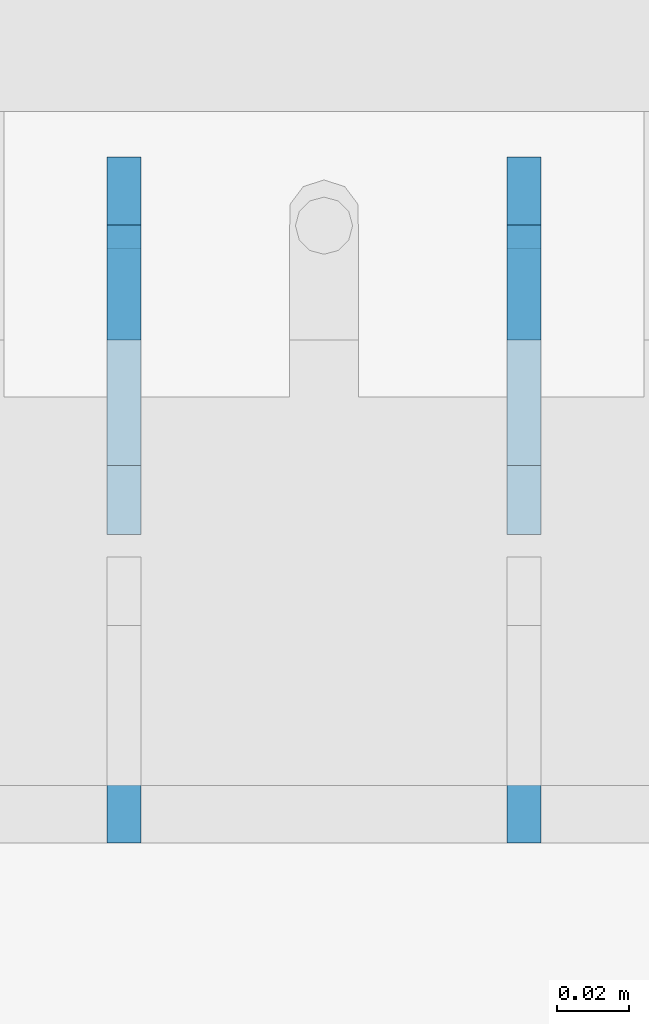
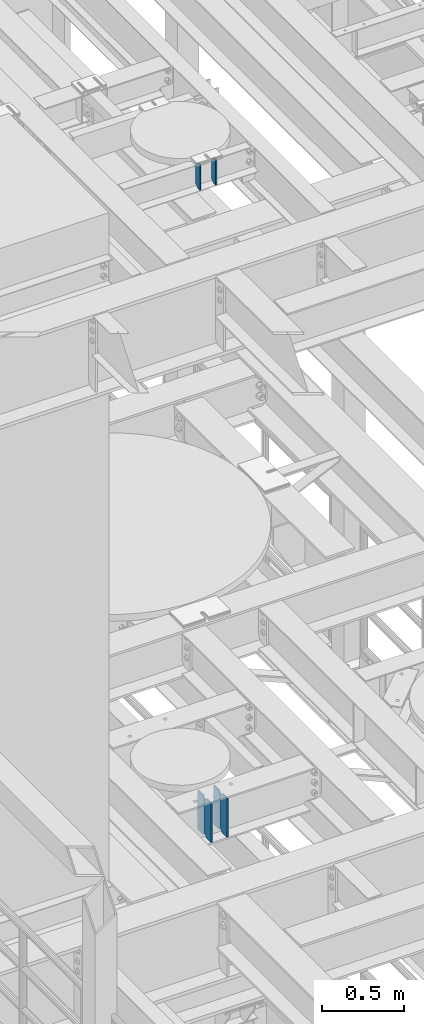
# One storey, part 1606 of 1876: 6 plates, 2 elements without a shape of their own.
"""IFC2X3 building model written with IfcOpenShell, lengths in millimetres."""

from ifc_helpers import new_model, si_unit, frame, origin_with_axes, place, context, subcontext, project, spatial, faceted_brep, material, type_object, element, aggregate, save


model = new_model("IFC2X3")

# Units and contexts
model_context = context("Model", 3, precision=1e-05, world=origin_with_axes())
body_context = subcontext(model_context, "Body", "Model", "MODEL_VIEW")
ifc_project = project(units=[si_unit("LENGTHUNIT", "METRE", prefix="MILLI"), si_unit("AREAUNIT", "SQUARE_METRE"), si_unit("VOLUMEUNIT", "CUBIC_METRE"), si_unit("MASSUNIT", "GRAM", prefix="KILO"), si_unit("TIMEUNIT", "SECOND"), si_unit("PLANEANGLEUNIT", "RADIAN"), si_unit("SOLIDANGLEUNIT", "STERADIAN"), si_unit("THERMODYNAMICTEMPERATUREUNIT", "DEGREE_CELSIUS"), si_unit("LUMINOUSINTENSITYUNIT", "LUMEN")], contexts=[model_context])

# Site, building, storey
site_placement = place(None, origin_with_axes())
site = spatial("IfcSite", under=ifc_project, at=site_placement, CompositionType="ELEMENT")
building_placement = place(site_placement, origin_with_axes())
building = spatial("IfcBuilding", under=site, at=building_placement, Name="Undefined", CompositionType="ELEMENT")
storey_placement = place(building_placement, origin_with_axes())
storey = spatial("IfcBuildingStorey", under=building, at=storey_placement, Name="Undefined", CompositionType="ELEMENT", Elevation=0.0)

# Assembly, plates
assembly_1_placement = place(storey_placement, origin_with_axes())
assembly_1 = element("IfcElementAssembly", 1, at=assembly_1_placement, inside=storey, Name="BEAM", AssemblyPlace="NOTDEFINED", PredefinedType="RIGID_FRAME")
ifc_material = material(Name="STEEL/A36")
plate_type_1 = type_object("IfcPlateType", PredefinedType="NOTDEFINED")
plate_1_placement = place(assembly_1_placement, frame((2544.762, 2336.8, 13006.3875), z_axis=(0.0, 0.0, 1.0), x_axis=(0.0, 1.0, 0.0)))
plate_1 = element("IfcPlate", 2, at=plate_1_placement, type_object=plate_type_1, material=ifc_material, Name="PLATE", context=body_context, shape_type="Brep", body=[
    faceted_brep([(0.0, -4.76249999999982, 0.0), (0.0, -4.76249999999982, 292.100006103516), (0.0, 4.76249999999982, 292.100006103516), (0.0, 4.76249999999982, 0.0), (60.3250007629395, -4.76249999999982, 292.100006103516), (60.3250007629395, 4.76249999999982, 292.100006103516), (79.375, -4.76249999999982, 273.050006866455), (79.375, 4.76249999999982, 273.050006866455), (79.375, -4.76249999999982, 19.0499992370605), (79.375, 4.76249999999982, 19.0499992370605), (60.3250007629395, -4.76249999999982, 0.0), (60.3250007629395, 4.76249999999982, 0.0)], [[[0, 1, 2, 3]], [[1, 4, 5, 2]], [[4, 6, 7, 5]], [[6, 8, 9, 7]], [[8, 10, 11, 9]], [[10, 0, 3, 11]], [[5, 7, 9, 11, 3, 2]], [[10, 8, 6, 4, 1, 0]]]),
])
plate_2_placement = place(assembly_1_placement, frame((2544.762, 2422.525, 13006.3875), z_axis=(0.0, 0.0, 1.0), x_axis=(0.0, 1.0, 0.0)))
plate_2 = element("IfcPlate", 3, at=plate_2_placement, type_object=plate_type_1, material=ifc_material, Name="PLATE", context=body_context, shape_type="Brep", body=[
    faceted_brep([(0.0, -4.76249999999982, 19.0499992370605), (0.0, -4.76249999999982, 273.050006866455), (0.0, 4.76249999999982, 273.050006866455), (0.0, 4.76249999999982, 19.0499992370605), (19.0499992370605, -4.76249999999982, 292.100006103516), (19.0499992370605, 4.76249999999982, 292.100006103516), (79.375, -4.76249999999982, 292.100006103516), (79.375, 4.76249999999982, 292.100006103516), (79.375, -4.76250000000073, 0.0), (79.375, 4.76250000000073, 0.0), (19.0499992370605, -4.76249999999982, 0.0), (19.0499992370605, 4.76249999999982, 0.0)], [[[0, 1, 2, 3]], [[1, 4, 5, 2]], [[4, 6, 7, 5]], [[6, 8, 9, 7]], [[8, 10, 11, 9]], [[10, 0, 3, 11]], [[5, 7, 9, 11, 3, 2]], [[10, 8, 6, 4, 1, 0]]]),
])
plate_3_placement = place(assembly_1_placement, frame((2433.6375, 2336.8, 13006.3875), z_axis=(0.0, 0.0, 1.0), x_axis=(0.0, 1.0, 0.0)))
plate_3 = element("IfcPlate", 4, at=plate_3_placement, type_object=plate_type_1, material=ifc_material, Name="PLATE", context=body_context, shape_type="Brep", body=[
    faceted_brep([(0.0, -4.76249999999982, 0.0), (0.0, -4.76249999999982, 292.100006103516), (0.0, 4.76249999999982, 292.100006103516), (0.0, 4.76249999999982, 0.0), (60.3250007629395, -4.76249999999982, 292.100006103516), (60.3250007629395, 4.76249999999982, 292.100006103516), (79.375, -4.76249999999982, 273.050006866455), (79.375, 4.76249999999982, 273.050006866455), (79.375, -4.76249999999982, 19.0499992370605), (79.375, 4.76249999999982, 19.0499992370605), (60.3250007629395, -4.76249999999982, 0.0), (60.3250007629395, 4.76249999999982, 0.0)], [[[0, 1, 2, 3]], [[1, 4, 5, 2]], [[4, 6, 7, 5]], [[6, 8, 9, 7]], [[8, 10, 11, 9]], [[10, 0, 3, 11]], [[5, 7, 9, 11, 3, 2]], [[10, 8, 6, 4, 1, 0]]]),
])
plate_4_placement = place(assembly_1_placement, frame((2433.6375, 2422.525, 13006.3875), z_axis=(0.0, 0.0, 1.0), x_axis=(0.0, 1.0, 0.0)))
plate_4 = element("IfcPlate", 5, at=plate_4_placement, type_object=plate_type_1, material=ifc_material, Name="PLATE", context=body_context, shape_type="Brep", body=[
    faceted_brep([(0.0, -4.76249999999982, 19.0499992370605), (0.0, -4.76249999999982, 273.050006866455), (0.0, 4.76249999999982, 273.050006866455), (0.0, 4.76249999999982, 19.0499992370605), (19.0499992370605, -4.76249999999982, 292.100006103516), (19.0499992370605, 4.76249999999982, 292.100006103516), (79.375, -4.76249999999982, 292.100006103516), (79.375, 4.76249999999982, 292.100006103516), (79.375, -4.76250000000073, 0.0), (79.375, 4.76250000000073, 0.0), (19.0499992370605, -4.76249999999982, 0.0), (19.0499992370605, 4.76249999999982, 0.0)], [[[0, 1, 2, 3]], [[1, 4, 5, 2]], [[4, 6, 7, 5]], [[6, 8, 9, 7]], [[8, 10, 11, 9]], [[10, 0, 3, 11]], [[5, 7, 9, 11, 3, 2]], [[10, 8, 6, 4, 1, 0]]]),
])
aggregate(assembly_1, [plate_1, plate_2, plate_3, plate_4])

assembly_2_placement = place(storey_placement, origin_with_axes())
assembly_2 = element("IfcElementAssembly", 6, at=assembly_2_placement, inside=storey, Name="BEAM", AssemblyPlace="NOTDEFINED", PredefinedType="RIGID_FRAME")
plate_type_2 = type_object("IfcPlateType", PredefinedType="NOTDEFINED")
plate_5_placement = place(assembly_2_placement, frame((2433.6375, 2476.5, 17784.2356641849), z_axis=(0.0, -0.164348325034458, 0.986402366206797), x_axis=(0.0, 0.986402366206797, 0.164348325034458)))
plate_5 = element("IfcPlate", 7, at=plate_5_placement, type_object=plate_type_2, material=ifc_material, Name="PLATE", context=body_context, shape_type="Brep", body=[
    faceted_brep([(0.0, -4.76249999999982, 0.0), (32.0008087158794, -4.76249999999982, 192.081680297815), (32.0008087158794, 4.76249999999982, 192.081680297815), (0.0, 4.76249999999982, 0.0), (62.6982748962027, -4.76249999999982, 181.561281061485), (62.6982748962027, 4.76249999999982, 181.561281061485), (77.5887637589458, -4.76249999999982, 156.594231983478), (77.5887637589458, 4.76249999999982, 156.594231983478), (54.6307491805464, -4.76249999999982, 18.791006663906), (54.6307491805464, 4.76249999999982, 18.791006663906), (32.4501686096137, -4.76249999999982, -1.63709046319127e-11), (32.4501686096137, 4.76249999999982, -1.63709046319127e-11)], [[[0, 1, 2, 3]], [[1, 4, 5, 2]], [[4, 6, 7, 5]], [[6, 8, 9, 7]], [[8, 10, 11, 9]], [[10, 0, 3, 11]], [[5, 7, 9, 11, 3, 2]], [[10, 8, 6, 4, 1, 0]]]),
])
plate_6_placement = place(assembly_2_placement, frame((2544.7625, 2476.5, 17784.2355895931), z_axis=(0.0, -0.164348325034458, 0.986402366206797), x_axis=(0.0, 0.986402366206797, 0.164348325034458)))
plate_6 = element("IfcPlate", 8, at=plate_6_placement, type_object=plate_type_2, material=ifc_material, Name="PLATE", context=body_context, shape_type="Brep", body=[
    faceted_brep([(0.0, -4.76249999999982, 0.0), (32.0008087158794, -4.76249999999982, 192.081680297815), (32.0008087158794, 4.76249999999982, 192.081680297815), (0.0, 4.76249999999982, 0.0), (62.6982748962027, -4.76249999999982, 181.561281061485), (62.6982748962027, 4.76249999999982, 181.561281061485), (77.5887637589458, -4.76249999999982, 156.594231983478), (77.5887637589458, 4.76249999999982, 156.594231983478), (54.6307491805464, -4.76249999999982, 18.791006663906), (54.6307491805464, 4.76249999999982, 18.791006663906), (32.4501686096137, -4.76249999999982, -1.63709046319127e-11), (32.4501686096137, 4.76249999999982, -1.63709046319127e-11)], [[[0, 1, 2, 3]], [[1, 4, 5, 2]], [[4, 6, 7, 5]], [[6, 8, 9, 7]], [[8, 10, 11, 9]], [[10, 0, 3, 11]], [[5, 7, 9, 11, 3, 2]], [[10, 8, 6, 4, 1, 0]]]),
])
aggregate(assembly_2, [plate_5, plate_6])

save(model, "model.ifc")
